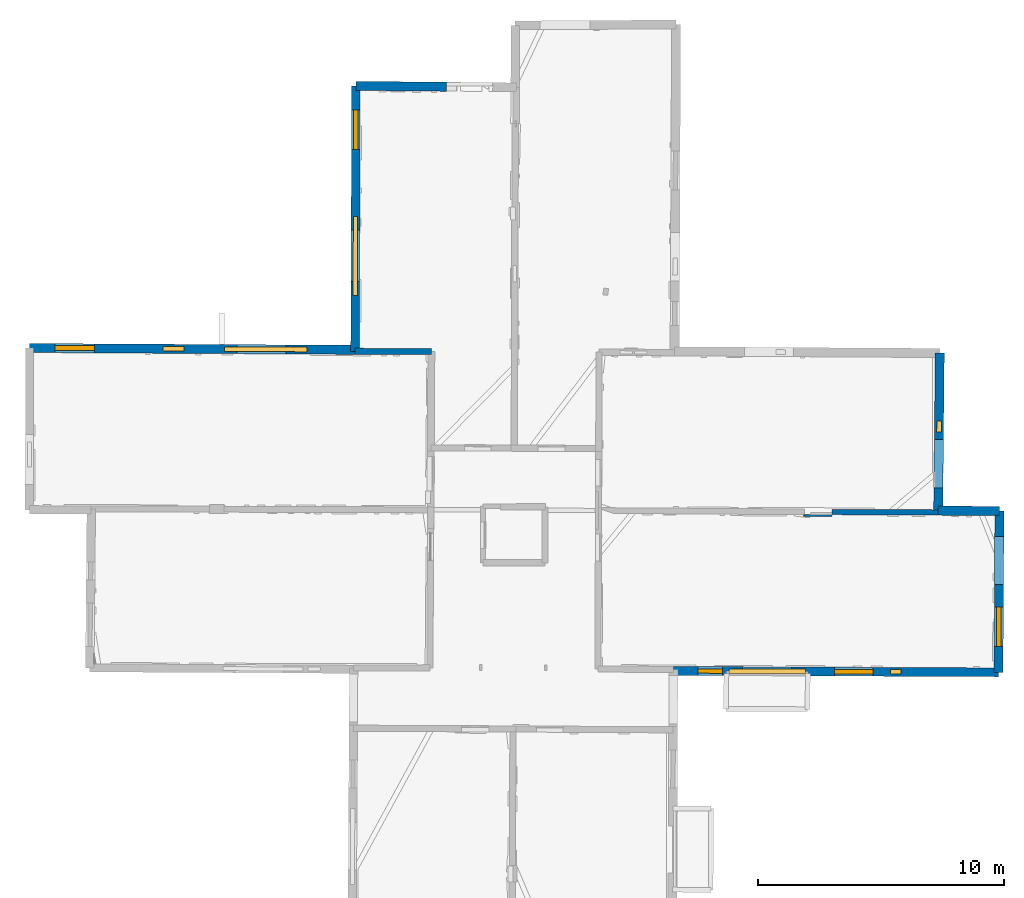
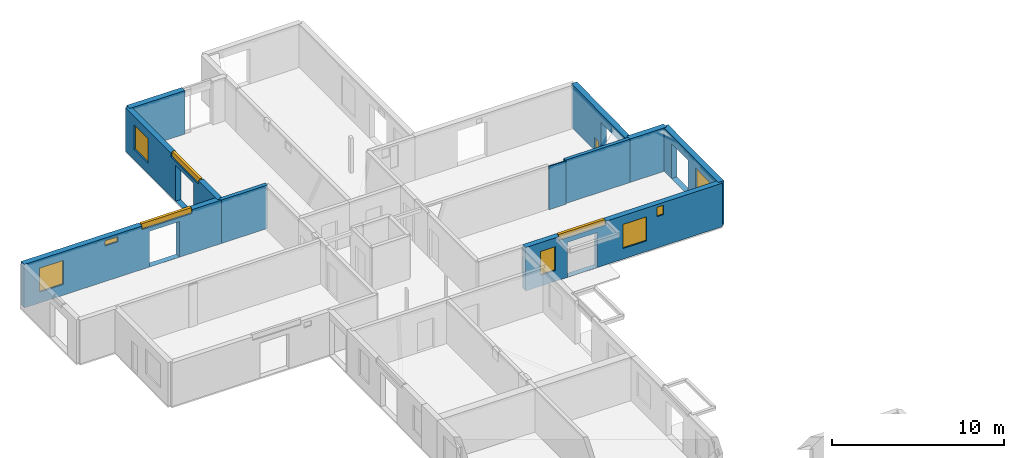
# One storey, part 9 of 15: 11 windows, 10 walls, 16 openings.
"""IFC2X3 building model written with IfcOpenShell, lengths in metres."""

from ifc_helpers import new_model, entity, si_unit, converted_unit, derived_unit, direction, frame, frame_2d, origin, origin_2d_with_axis, place, context, subcontext, project, spatial, polyline, rectangle, outline, extrude, source, transform, mapped, material, layer, layer_set, layer_usage, type_object, type_shapes, element, fill, save


model = new_model("IFC2X3")

# Units and contexts
model_context = context("Model", 3, precision=1e-05, world=origin(), true_north=direction((0.0, 1.0)))
body_context = subcontext(model_context, "Body", "Model", "MODEL_VIEW")
ifc_project = project(units=[si_unit("LENGTHUNIT", "METRE"), si_unit("AREAUNIT", "SQUARE_METRE"), si_unit("VOLUMEUNIT", "CUBIC_METRE"), converted_unit("PLANEANGLEUNIT", "DEGREE", entity("IfcRatioMeasure", 0.0174532925199433), si_unit("PLANEANGLEUNIT", "RADIAN"), dimensions=[0, 0, 0, 0, 0, 0, 0]), si_unit("MASSUNIT", "GRAM", prefix="KILO"), derived_unit("MASSDENSITYUNIT", [(si_unit("MASSUNIT", "GRAM", prefix="KILO"), 1), (si_unit("LENGTHUNIT", "METRE"), -3)]), derived_unit("MOMENTOFINERTIAUNIT", [(si_unit("LENGTHUNIT", "METRE"), 4)]), si_unit("TIMEUNIT", "SECOND"), si_unit("FREQUENCYUNIT", "HERTZ"), si_unit("THERMODYNAMICTEMPERATUREUNIT", "DEGREE_CELSIUS"), derived_unit("THERMALTRANSMITTANCEUNIT", [(si_unit("MASSUNIT", "GRAM", prefix="KILO"), 1), (si_unit("THERMODYNAMICTEMPERATUREUNIT", "KELVIN"), -1), (si_unit("TIMEUNIT", "SECOND"), -3)]), derived_unit("VOLUMETRICFLOWRATEUNIT", [(si_unit("LENGTHUNIT", "METRE"), 3), (si_unit("TIMEUNIT", "SECOND"), -1)]), si_unit("ELECTRICCURRENTUNIT", "AMPERE"), si_unit("ELECTRICVOLTAGEUNIT", "VOLT"), si_unit("POWERUNIT", "WATT"), si_unit("FORCEUNIT", "NEWTON", prefix="KILO"), si_unit("ILLUMINANCEUNIT", "LUX"), si_unit("LUMINOUSFLUXUNIT", "LUMEN"), si_unit("LUMINOUSINTENSITYUNIT", "CANDELA"), derived_unit("USERDEFINED", [(si_unit("MASSUNIT", "GRAM", prefix="KILO"), -1), (si_unit("LENGTHUNIT", "METRE"), -2), (si_unit("TIMEUNIT", "SECOND"), 3), (si_unit("LUMINOUSFLUXUNIT", "LUMEN"), 1)]), derived_unit("LINEARVELOCITYUNIT", [(si_unit("LENGTHUNIT", "METRE"), 1), (si_unit("TIMEUNIT", "SECOND"), -1)]), si_unit("PRESSUREUNIT", "PASCAL"), derived_unit("USERDEFINED", [(si_unit("LENGTHUNIT", "METRE"), -2), (si_unit("MASSUNIT", "GRAM", prefix="KILO"), 1), (si_unit("TIMEUNIT", "SECOND"), -2)]), derived_unit("LINEARFORCEUNIT", [(si_unit("MASSUNIT", "GRAM", prefix="KILO"), 1), (si_unit("LENGTHUNIT", "METRE"), 1), (si_unit("TIMEUNIT", "SECOND"), -2), (si_unit("LENGTHUNIT", "METRE"), -1)]), derived_unit("PLANARFORCEUNIT", [(si_unit("MASSUNIT", "GRAM", prefix="KILO"), 1), (si_unit("LENGTHUNIT", "METRE"), 1), (si_unit("TIMEUNIT", "SECOND"), -2), (si_unit("LENGTHUNIT", "METRE"), -2)])], contexts=[model_context])

# Site, building, storey
placement = place(None, origin())
site = spatial("IfcSite", under=ifc_project, at=placement, CompositionType="ELEMENT")
building = spatial("IfcBuilding", under=site, at=placement, CompositionType="ELEMENT")
storey_placement = place(placement, frame((0.0, 0.0, 2.3807327747345)))
storey = spatial("IfcBuildingStorey", under=building, at=storey_placement, Name="Level 2", CompositionType="ELEMENT", Elevation=2.3807327747345)

# Wall
ifc_material_1 = material(Name="Default wall")
ifc_layer_1 = layer(ifc_material_1, 0.25)
ifc_layer_set_1 = layer_set([ifc_layer_1], Name="wall_thickness_0.2500")
ifc_layer_usage_1 = layer_usage(ifc_layer_set_1, "AXIS2", "POSITIVE", -0.125)
wall_type_1 = type_object("IfcWallType", Name="wall_thickness_0.2500", PredefinedType="STANDARD", material=ifc_layer_set_1)
wall_1_placement = place(storey_placement, frame((-0.0906764365167786, 64.0786910572292, 0.0), z_axis=(0.0, 0.0, 1.0), x_axis=(0.999988151663691, -0.0048679084044511, 0.0)))
element("IfcWallStandardCase", 1, at=wall_1_placement, inside=storey, type_object=wall_type_1, material=ifc_layer_usage_1, Name="Wall:691", ObjectType="Wall", context=body_context, shape_type="SweptSolid", body=[
    extrude(outline(polyline([(3.09695301168057, -0.125), (3.09695301168057, 0.125), (0.0, 0.125), (0.0, -0.125), (3.09695301168057, -0.125)])), origin(), (0.0, 0.0, 1.0), 3.08589615821838),
])

# Wall, openings, windows
ifc_layer_2 = layer(ifc_material_1, 0.349999994039536)
ifc_layer_set_2 = layer_set([ifc_layer_2], Name="wall_thickness_0.3500")
ifc_layer_usage_2 = layer_usage(ifc_layer_set_2, "AXIS2", "POSITIVE", -0.174999997019768)
wall_type_2 = type_object("IfcWallType", Name="wall_thickness_0.3500", PredefinedType="STANDARD", material=ifc_layer_set_2)
wall_2_placement = place(storey_placement, frame((-0.0535053161147532, 74.8457627418778, 0.0), z_axis=(0.0, 0.0, 1.0), x_axis=(-0.00345223117445112, -0.999994041032204, 0.0)))
wall_2 = element("IfcWallStandardCase", 2, at=wall_2_placement, inside=storey, type_object=wall_type_2, material=ifc_layer_usage_2, Name="Wall:695", ObjectType="Wall", context=body_context, shape_type="SweptSolid", body=[
    extrude(outline(polyline([(10.767146375434, -0.174999997019768), (10.767146375434, 0.174999997019768), (0.0, 0.174999997019768), (0.0, -0.174999997019768), (10.767146375434, -0.174999997019768)])), origin(), (0.0, 0.0, 1.0), 3.08589615821838),
])
opening_1_placement = place(wall_2_placement, frame((5.84369326956911, -0.174999997019768, 0.00526785850524902)))
element("IfcOpeningElement", 3, at=opening_1_placement, cuts=wall_2, Name="Opening : 2095 x 2525 : 438", ObjectType="Opening", context=body_context, shape_type="SweptSolid", body=[
    extrude(rectangle(XDim=2.095, YDim=2.525, at=frame_2d((1.2625, 1.0475), x_axis=(0.0, 1.0))), frame((0.0, 0.0, 0.0), z_axis=(0.0, 1.0, 0.0), x_axis=(0.0, 0.0, 1.0)), (0.0, 0.0, 1.0), 0.349999994039536),
])
opening_2_placement = place(wall_2_placement, frame((5.28984933202221, -0.174999997019768, 2.83026766777039)))
opening_2 = element("IfcOpeningElement", 4, at=opening_2_placement, cuts=wall_2, Name="Opening : 3210 x 345 : 439", ObjectType="Opening", context=body_context, shape_type="SweptSolid", body=[
    extrude(rectangle(XDim=3.21, YDim=0.345, at=frame_2d((0.1725, 1.605), x_axis=(0.0, 1.0))), frame((0.0, 0.0, 0.0), z_axis=(0.0, 1.0, 0.0), x_axis=(0.0, 0.0, 1.0)), (0.0, 0.0, 1.0), 0.349999994039536),
])
opening_3_placement = place(wall_2_placement, frame((0.969854412022947, -0.174999997019768, 0.735267639160156)))
opening_3 = element("IfcOpeningElement", 5, at=opening_3_placement, cuts=wall_2, Name="Opening : 1620 x 1745 : 440", ObjectType="Opening", context=body_context, shape_type="SweptSolid", body=[
    extrude(rectangle(XDim=1.62, YDim=1.745, at=frame_2d((0.8725, 0.81), x_axis=(0.0, 1.0))), frame((0.0, 0.0, 0.0), z_axis=(0.0, 1.0, 0.0), x_axis=(0.0, 0.0, 1.0)), (0.0, 0.0, 1.0), 0.349999994039536),
])
ifc_material_2 = material(Name="Window Default")
window_style_1 = type_object("IfcWindowStyle", Name="Window : 3210 x 345mm", ConstructionType="NOTDEFINED", OperationType="NOTDEFINED", ParameterTakesPrecedence=False, Sizeable=False, material=ifc_material_2)
shared_shape_1 = source(origin(), body_context, "Body", "SweptSolid", [
    extrude(rectangle(XDim=0.174999997019768, YDim=3.21, at=origin_2d_with_axis()), frame((1.605, 0.174999997019768, 0.0), z_axis=(0.0, 0.0, 1.0), x_axis=(0.0, 1.0, 0.0)), (0.0, 0.0, 1.0), 0.345),
])
type_shapes(window_style_1, [shared_shape_1])
window_1_placement = place(opening_2_placement, origin())
window_1 = element("IfcWindow", 6, at=window_1_placement, inside=storey, type_object=window_style_1, Name="Window : 3210 x 345mm : 239", ObjectType="Window : 3210 x 345mm", OverallHeight=0.345, OverallWidth=3.21, context=body_context, shape_type="MappedRepresentation", body=[
    mapped(shared_shape_1, transform((0.0, 0.0, 0.0), scale=1.0)),
])
fill(opening_2, window_1)
window_style_2 = type_object("IfcWindowStyle", Name="Window : 1620 x 1745mm", ConstructionType="NOTDEFINED", OperationType="NOTDEFINED", ParameterTakesPrecedence=False, Sizeable=False, material=ifc_material_2)
shared_shape_2 = source(origin(), body_context, "Body", "SweptSolid", [
    extrude(rectangle(XDim=0.174999997019768, YDim=1.62, at=origin_2d_with_axis()), frame((0.81, 0.174999997019768, 0.0), z_axis=(0.0, 0.0, 1.0), x_axis=(0.0, 1.0, 0.0)), (0.0, 0.0, 1.0), 1.745),
])
type_shapes(window_style_2, [shared_shape_2])
window_2_placement = place(opening_3_placement, origin())
window_2 = element("IfcWindow", 7, at=window_2_placement, inside=storey, type_object=window_style_2, Name="Window : 1620 x 1745mm : 240", ObjectType="Window : 1620 x 1745mm", OverallHeight=1.745, OverallWidth=1.62, context=body_context, shape_type="MappedRepresentation", body=[
    mapped(shared_shape_2, transform((0.0, 0.0, 0.0), scale=1.0)),
])
fill(opening_3, window_2)

ifc_layer_3 = layer(ifc_material_1, 0.370000004768372)
ifc_layer_set_3 = layer_set([ifc_layer_3], Name="wall_thickness_0.3700")
ifc_layer_usage_3 = layer_usage(ifc_layer_set_3, "AXIS2", "POSITIVE", -0.185000002384186)
wall_type_3 = type_object("IfcWallType", Name="wall_thickness_0.3700", PredefinedType="STANDARD", material=ifc_layer_set_3)
wall_3_placement = place(storey_placement, frame((-13.2956305764581, 64.2113955876942, 0.0), z_axis=(0.0, 0.0, 1.0), x_axis=(0.999985026061167, -0.00547244492409057, 0.0)))
wall_3 = element("IfcWallStandardCase", 8, at=wall_3_placement, inside=storey, type_object=wall_type_3, material=ifc_layer_usage_3, Name="Wall:727", ObjectType="Wall", context=body_context, shape_type="SweptSolid", body=[
    extrude(outline(polyline([(13.2053635993439, -0.185000002384186), (13.2053635993439, 0.185000002384186), (0.0, 0.185000002384186), (0.0, -0.185000002384186), (13.2053635993439, -0.185000002384186)])), origin(), (0.0, 0.0, 1.0), 3.08589615821838),
])
opening_4_placement = place(wall_3_placement, frame((8.41019351553604, -0.185000002384186, 0.00526785850524902)))
element("IfcOpeningElement", 9, at=opening_4_placement, cuts=wall_3, Name="Opening : 1985 x 2525 : 462", ObjectType="Opening", context=body_context, shape_type="SweptSolid", body=[
    extrude(rectangle(XDim=1.985, YDim=2.525, at=frame_2d((1.2625, 0.9925), x_axis=(0.0, 1.0))), frame((0.0, 0.0, 0.0), z_axis=(0.0, 1.0, 0.0), x_axis=(0.0, 0.0, 1.0)), (0.0, 0.0, 1.0), 0.370000004768372),
])
opening_5_placement = place(wall_3_placement, frame((5.42322892999086, -0.185000002384186, 2.52226710319519)))
opening_5 = element("IfcOpeningElement", 10, at=opening_5_placement, cuts=wall_3, Name="Opening : 850 x 365 : 463", ObjectType="Opening", context=body_context, shape_type="SweptSolid", body=[
    extrude(rectangle(XDim=0.85, YDim=0.365, at=frame_2d((0.1825, 0.425), x_axis=(0.0, 1.0))), frame((0.0, 0.0, 0.0), z_axis=(0.0, 1.0, 0.0), x_axis=(0.0, 0.0, 1.0)), (0.0, 0.0, 1.0), 0.370000004768372),
])
opening_6_placement = place(wall_3_placement, frame((1.04019153019943, -0.185000002384186, 0.765267610549927)))
opening_6 = element("IfcOpeningElement", 11, at=opening_6_placement, cuts=wall_3, Name="Opening : 1590 x 1705 : 464", ObjectType="Opening", context=body_context, shape_type="SweptSolid", body=[
    extrude(rectangle(XDim=1.59, YDim=1.705, at=frame_2d((0.8525, 0.795), x_axis=(0.0, 1.0))), frame((0.0, 0.0, 0.0), z_axis=(0.0, 1.0, 0.0), x_axis=(0.0, 0.0, 1.0)), (0.0, 0.0, 1.0), 0.370000004768372),
])
opening_7_placement = place(wall_3_placement, frame((7.9017835414809, -0.185000002384186, 2.82026743888855)))
opening_7 = element("IfcOpeningElement", 12, at=opening_7_placement, cuts=wall_3, Name="Opening : 3350 x 355 : 465", ObjectType="Opening", context=body_context, shape_type="SweptSolid", body=[
    extrude(rectangle(XDim=3.35, YDim=0.355, at=frame_2d((0.1775, 1.675), x_axis=(0.0, 1.0))), frame((0.0, 0.0, 0.0), z_axis=(0.0, 1.0, 0.0), x_axis=(0.0, 0.0, 1.0)), (0.0, 0.0, 1.0), 0.370000004768372),
])
window_style_3 = type_object("IfcWindowStyle", Name="Window : 1590 x 1705mm", ConstructionType="NOTDEFINED", OperationType="NOTDEFINED", ParameterTakesPrecedence=False, Sizeable=False, material=ifc_material_2)
shared_shape_3 = source(origin(), body_context, "Body", "SweptSolid", [
    extrude(rectangle(XDim=0.194999992847443, YDim=1.59, at=origin_2d_with_axis()), frame((0.795, 0.194999992847443, 0.0), z_axis=(0.0, 0.0, 1.0), x_axis=(0.0, 1.0, 0.0)), (0.0, 0.0, 1.0), 1.705),
])
type_shapes(window_style_3, [shared_shape_3])
window_3_placement = place(opening_6_placement, origin())
window_3 = element("IfcWindow", 13, at=window_3_placement, inside=storey, type_object=window_style_3, Name="Window : 1590 x 1705mm : 252", ObjectType="Window : 1590 x 1705mm", OverallHeight=1.705, OverallWidth=1.59, context=body_context, shape_type="MappedRepresentation", body=[
    mapped(shared_shape_3, transform((0.0, 0.0, 0.0), scale=1.0)),
])
fill(opening_6, window_3)
window_style_4 = type_object("IfcWindowStyle", Name="Window : 850 x 365mm", ConstructionType="NOTDEFINED", OperationType="NOTDEFINED", ParameterTakesPrecedence=False, Sizeable=False, material=ifc_material_2)
shared_shape_4 = source(origin(), body_context, "Body", "SweptSolid", [
    extrude(rectangle(XDim=0.185000002384186, YDim=0.85, at=origin_2d_with_axis()), frame((0.425, 0.185000002384186, 0.0), z_axis=(0.0, 0.0, 1.0), x_axis=(0.0, 1.0, 0.0)), (0.0, 0.0, 1.0), 0.365),
])
type_shapes(window_style_4, [shared_shape_4])
window_4_placement = place(opening_5_placement, origin())
window_4 = element("IfcWindow", 14, at=window_4_placement, inside=storey, type_object=window_style_4, Name="Window : 850 x 365mm : 251", ObjectType="Window : 850 x 365mm", OverallHeight=0.365, OverallWidth=0.85, context=body_context, shape_type="MappedRepresentation", body=[
    mapped(shared_shape_4, transform((0.0, 0.0, 0.0), scale=1.0)),
])
fill(opening_5, window_4)
window_style_5 = type_object("IfcWindowStyle", Name="Window : 3350 x 355mm", ConstructionType="NOTDEFINED", OperationType="NOTDEFINED", ParameterTakesPrecedence=False, Sizeable=False, material=ifc_material_2)
shared_shape_5 = source(origin(), body_context, "Body", "SweptSolid", [
    extrude(rectangle(XDim=0.185000002384186, YDim=3.35, at=origin_2d_with_axis()), frame((1.675, 0.185000002384186, 0.0), z_axis=(0.0, 0.0, 1.0), x_axis=(0.0, 1.0, 0.0)), (0.0, 0.0, 1.0), 0.355),
])
type_shapes(window_style_5, [shared_shape_5])
window_5_placement = place(opening_7_placement, origin())
window_5 = element("IfcWindow", 15, at=window_5_placement, inside=storey, type_object=window_style_5, Name="Window : 3350 x 355mm : 253", ObjectType="Window : 3350 x 355mm", OverallHeight=0.355, OverallWidth=3.35, context=body_context, shape_type="MappedRepresentation", body=[
    mapped(shared_shape_5, transform((0.0, 0.0, 0.0), scale=1.0)),
])
fill(opening_7, window_5)

# Wall, openings, window
wall_4_placement = place(storey_placement, frame((23.6338339024717, 64.0098037092952, 0.0), z_axis=(0.0, 0.0, 1.0), x_axis=(-0.00993887533484654, -0.999950608158762, 0.0)))
wall_4 = element("IfcWallStandardCase", 16, at=wall_4_placement, inside=storey, type_object=wall_type_3, material=ifc_layer_usage_3, Name="Wall:732", ObjectType="Wall", context=body_context, shape_type="SweptSolid", body=[
    extrude(outline(polyline([(6.39801727328113, -0.185000002384186), (6.39801727328113, 0.185000002384186), (0.0, 0.185000002384186), (0.0, -0.185000002384186), (6.39801727328113, -0.185000002384186)])), origin(), (0.0, 0.0, 1.0), 3.08589615821838),
])
opening_8_placement = place(wall_4_placement, frame((3.50378744257806, -0.185000002384186, 0.00526785850524902)))
element("IfcOpeningElement", 17, at=opening_8_placement, cuts=wall_4, Name="Opening : 1970 x 2450 : 471", ObjectType="Opening", context=body_context, shape_type="SweptSolid", body=[
    extrude(rectangle(XDim=1.97, YDim=2.45, at=frame_2d((1.225, 0.985), x_axis=(0.0, 1.0))), frame((0.0, 0.0, 0.0), z_axis=(0.0, 1.0, 0.0), x_axis=(0.0, 0.0, 1.0)), (0.0, 0.0, 1.0), 0.370000004768372),
])
opening_9_placement = place(wall_4_placement, frame((2.75626248104997, -0.185000002384186, 0.0972676277160645)))
opening_9 = element("IfcOpeningElement", 18, at=opening_9_placement, cuts=wall_4, Name="Opening : 445 x 825 : 472", ObjectType="Opening", context=body_context, shape_type="SweptSolid", body=[
    extrude(rectangle(XDim=0.445, YDim=0.825, at=frame_2d((0.4125, 0.2225), x_axis=(0.0, 1.0))), frame((0.0, 0.0, 0.0), z_axis=(0.0, 1.0, 0.0), x_axis=(0.0, 0.0, 1.0)), (0.0, 0.0, 1.0), 0.370000004768372),
])
window_style_6 = type_object("IfcWindowStyle", Name="Window : 445 x 825mm", ConstructionType="NOTDEFINED", OperationType="NOTDEFINED", ParameterTakesPrecedence=False, Sizeable=False, material=ifc_material_2)
shared_shape_6 = source(origin(), body_context, "Body", "SweptSolid", [
    extrude(rectangle(XDim=0.185000002384186, YDim=0.445, at=origin_2d_with_axis()), frame((0.2225, 0.185000002384186, 0.0), z_axis=(0.0, 0.0, 1.0), x_axis=(0.0, 1.0, 0.0)), (0.0, 0.0, 1.0), 0.825),
])
type_shapes(window_style_6, [shared_shape_6])
window_6_placement = place(opening_9_placement, origin())
window_6 = element("IfcWindow", 19, at=window_6_placement, inside=storey, type_object=window_style_6, Name="Window : 445 x 825mm : 258", ObjectType="Window : 445 x 825mm", OverallHeight=0.825, OverallWidth=0.445, context=body_context, shape_type="MappedRepresentation", body=[
    mapped(shared_shape_6, transform((0.0, 0.0, 0.0), scale=1.0)),
])
fill(opening_9, window_6)

wall_5_placement = place(storey_placement, frame((26.0540302055587, 57.6021826031562, 0.0), z_axis=(0.0, 0.0, 1.0), x_axis=(-0.0058675588837642, -0.999982785728207, 0.0)))
wall_5 = element("IfcWallStandardCase", 20, at=wall_5_placement, inside=storey, type_object=wall_type_3, material=ifc_layer_usage_3, Name="Wall:770", ObjectType="Wall", context=body_context, shape_type="SweptSolid", body=[
    extrude(outline(polyline([(6.54879589925643, -0.185000002384186), (6.54879589925643, 0.185000002384186), (0.0, 0.185000002384186), (0.0, -0.185000002384186), (6.54879589925643, -0.185000002384186)])), origin(), (0.0, 0.0, 1.0), 3.08589615821838),
])
opening_10_placement = place(wall_5_placement, frame((1.03357187199044, -0.185000002384186, 0.00526785850524902)))
element("IfcOpeningElement", 21, at=opening_10_placement, cuts=wall_5, Name="Opening : 1945 x 2475 : 487", ObjectType="Opening", context=body_context, shape_type="SweptSolid", body=[
    extrude(rectangle(XDim=1.945, YDim=2.475, at=frame_2d((1.2375, 0.9725), x_axis=(0.0, 1.0))), frame((0.0, 0.0, 0.0), z_axis=(0.0, 1.0, 0.0), x_axis=(0.0, 0.0, 1.0)), (0.0, 0.0, 1.0), 0.370000004768372),
])
opening_11_placement = place(wall_5_placement, frame((3.89857327184577, -0.185000002384186, 0.750267744064331)))
opening_11 = element("IfcOpeningElement", 22, at=opening_11_placement, cuts=wall_5, Name="Opening : 1610 x 1735 : 488", ObjectType="Opening", context=body_context, shape_type="SweptSolid", body=[
    extrude(rectangle(XDim=1.61, YDim=1.735, at=frame_2d((0.8675, 0.805), x_axis=(0.0, 1.0))), frame((0.0, 0.0, 0.0), z_axis=(0.0, 1.0, 0.0), x_axis=(0.0, 0.0, 1.0)), (0.0, 0.0, 1.0), 0.370000004768372),
])
window_style_7 = type_object("IfcWindowStyle", Name="Window : 1610 x 1735mm", ConstructionType="NOTDEFINED", OperationType="NOTDEFINED", ParameterTakesPrecedence=False, Sizeable=False, material=ifc_material_2)
shared_shape_7 = source(origin(), body_context, "Body", "SweptSolid", [
    extrude(rectangle(XDim=0.185000002384186, YDim=1.61, at=origin_2d_with_axis()), frame((0.805, 0.185000002384186, 0.0), z_axis=(0.0, 0.0, 1.0), x_axis=(0.0, 1.0, 0.0)), (0.0, 0.0, 1.0), 1.735),
])
type_shapes(window_style_7, [shared_shape_7])
window_7_placement = place(opening_11_placement, origin())
window_7 = element("IfcWindow", 23, at=window_7_placement, inside=storey, type_object=window_style_7, Name="Window : 1610 x 1735mm : 262", ObjectType="Window : 1610 x 1735mm", OverallHeight=1.735, OverallWidth=1.61, context=body_context, shape_type="MappedRepresentation", body=[
    mapped(shared_shape_7, transform((0.0, 0.0, 0.0), scale=1.0)),
])
fill(opening_11, window_7)

# Walls
wall_6_placement = place(storey_placement, frame((-0.0535056053142751, 74.8457545391569, 0.0), z_axis=(0.0, 0.0, 1.0), x_axis=(0.999956328217215, -0.00934567591699247, 0.0)))
element("IfcWallStandardCase", 24, at=wall_6_placement, inside=storey, type_object=wall_type_3, material=ifc_layer_usage_3, Name="Wall:776", ObjectType="Wall", context=body_context, shape_type="SweptSolid", body=[
    extrude(outline(polyline([(3.67686545884509, -0.185000002384186), (3.67686545884509, 0.185000002384186), (0.0, 0.185000002384186), (0.0, -0.185000002384186), (3.67686545884509, -0.185000002384186)])), origin(), (0.0, 0.0, 1.0), 3.08589615821838),
])
wall_7_placement = place(storey_placement, frame((23.5702423383053, 57.6121091727195, 0.0), z_axis=(0.0, 0.0, 1.0), x_axis=(0.999992002823346, -0.00399928610536758, 0.0)))
element("IfcWallStandardCase", 25, at=wall_7_placement, inside=storey, type_object=wall_type_3, material=ifc_layer_usage_3, Name="Wall:793", ObjectType="Wall", context=body_context, shape_type="SweptSolid", body=[
    extrude(outline(polyline([(2.48381121479542, -0.185000002384186), (2.48381121479542, 0.185000002384186), (0.0, 0.185000002384186), (0.0, -0.185000002384186), (2.48381121479542, -0.185000002384186)])), origin(), (0.0, 0.0, 1.0), 3.08589615821838),
])

# Wall, openings, windows
ifc_layer_4 = layer(ifc_material_1, 0.360000014305115)
ifc_layer_set_4 = layer_set([ifc_layer_4], Name="wall_thickness_0.3600")
ifc_layer_usage_4 = layer_usage(ifc_layer_set_4, "AXIS2", "POSITIVE", -0.180000007152557)
wall_type_4 = type_object("IfcWallType", Name="wall_thickness_0.3600", PredefinedType="STANDARD", material=ifc_layer_set_4)
wall_8_placement = place(storey_placement, frame((12.8278243343549, 51.1126649744231, 0.0), z_axis=(0.0, 0.0, 1.0), x_axis=(0.999989936164332, -0.00448637604913739, 0.0)))
wall_8 = element("IfcWallStandardCase", 26, at=wall_8_placement, inside=storey, type_object=wall_type_4, material=ifc_layer_usage_4, Name="Wall:711", ObjectType="Wall", context=body_context, shape_type="SweptSolid", body=[
    extrude(outline(polyline([(13.1879169159749, -0.180000007152557), (13.1879169159749, 0.180000007152557), (0.0, 0.180000007152557), (0.0, -0.180000007152557), (13.1879169159749, -0.180000007152557)])), origin(), (0.0, 0.0, 1.0), 3.08589615821838),
])
opening_12_placement = place(wall_8_placement, frame((2.7985416494574, -0.180000007152557, 0.00526785850524902)))
element("IfcOpeningElement", 27, at=opening_12_placement, cuts=wall_8, Name="Opening : 2000 x 2480 : 449", ObjectType="Opening", context=body_context, shape_type="SweptSolid", body=[
    extrude(rectangle(XDim=2.0, YDim=2.48, at=frame_2d((1.24, 1.0), x_axis=(0.0, 1.0))), frame((0.0, 0.0, 0.0), z_axis=(0.0, 1.0, 0.0), x_axis=(0.0, 0.0, 1.0)), (0.0, 0.0, 1.0), 0.360000014305115),
])
opening_13_placement = place(wall_8_placement, frame((2.24581317396792, -0.180000007152557, 2.82026743888855)))
opening_13 = element("IfcOpeningElement", 28, at=opening_13_placement, cuts=wall_8, Name="Opening : 3105 x 355 : 450", ObjectType="Opening", context=body_context, shape_type="SweptSolid", body=[
    extrude(rectangle(XDim=3.105, YDim=0.355, at=frame_2d((0.1775, 1.5525), x_axis=(0.0, 1.0))), frame((0.0, 0.0, 0.0), z_axis=(0.0, 1.0, 0.0), x_axis=(0.0, 0.0, 1.0)), (0.0, 0.0, 1.0), 0.360000014305115),
])
opening_14_placement = place(wall_8_placement, frame((8.79695596446889, -0.180000007152557, 2.2272675037384)))
opening_14 = element("IfcOpeningElement", 29, at=opening_14_placement, cuts=wall_8, Name="Opening : 435 x 655 : 451", ObjectType="Opening", context=body_context, shape_type="SweptSolid", body=[
    extrude(rectangle(XDim=0.435, YDim=0.655, at=frame_2d((0.3275, 0.2175), x_axis=(0.0, 1.0))), frame((0.0, 0.0, 0.0), z_axis=(0.0, 1.0, 0.0), x_axis=(0.0, 0.0, 1.0)), (0.0, 0.0, 1.0), 0.360000014305115),
])
opening_15_placement = place(wall_8_placement, frame((0.998539538124343, -0.180000007152557, 0.775267839431763)))
opening_15 = element("IfcOpeningElement", 30, at=opening_15_placement, cuts=wall_8, Name="Opening : 990 x 1690 : 452", ObjectType="Opening", context=body_context, shape_type="SweptSolid", body=[
    extrude(rectangle(XDim=0.99, YDim=1.69, at=frame_2d((0.845, 0.495), x_axis=(0.0, 1.0))), frame((0.0, 0.0, 0.0), z_axis=(0.0, 1.0, 0.0), x_axis=(0.0, 0.0, 1.0)), (0.0, 0.0, 1.0), 0.360000014305115),
])
opening_16_placement = place(wall_8_placement, frame((6.52854056973658, -0.180000007152557, 0.750267744064331)))
opening_16 = element("IfcOpeningElement", 31, at=opening_16_placement, cuts=wall_8, Name="Opening : 1565 x 1715 : 453", ObjectType="Opening", context=body_context, shape_type="SweptSolid", body=[
    extrude(rectangle(XDim=1.565, YDim=1.715, at=frame_2d((0.8575, 0.7825), x_axis=(0.0, 1.0))), frame((0.0, 0.0, 0.0), z_axis=(0.0, 1.0, 0.0), x_axis=(0.0, 0.0, 1.0)), (0.0, 0.0, 1.0), 0.360000014305115),
])
window_style_8 = type_object("IfcWindowStyle", Name="Window : 3105 x 355mm", ConstructionType="NOTDEFINED", OperationType="NOTDEFINED", ParameterTakesPrecedence=False, Sizeable=False, material=ifc_material_2)
shared_shape_8 = source(origin(), body_context, "Body", "SweptSolid", [
    extrude(rectangle(XDim=0.180000007152557, YDim=3.105, at=origin_2d_with_axis()), frame((1.5525, 0.180000007152557, 0.0), z_axis=(0.0, 0.0, 1.0), x_axis=(0.0, 1.0, 0.0)), (0.0, 0.0, 1.0), 0.355),
])
type_shapes(window_style_8, [shared_shape_8])
window_8_placement = place(opening_13_placement, origin())
window_8 = element("IfcWindow", 32, at=window_8_placement, inside=storey, type_object=window_style_8, Name="Window : 3105 x 355mm : 243", ObjectType="Window : 3105 x 355mm", OverallHeight=0.355, OverallWidth=3.105, context=body_context, shape_type="MappedRepresentation", body=[
    mapped(shared_shape_8, transform((0.0, 0.0, 0.0), scale=1.0)),
])
fill(opening_13, window_8)
window_style_9 = type_object("IfcWindowStyle", Name="Window : 435 x 655mm", ConstructionType="NOTDEFINED", OperationType="NOTDEFINED", ParameterTakesPrecedence=False, Sizeable=False, material=ifc_material_2)
shared_shape_9 = source(origin(), body_context, "Body", "SweptSolid", [
    extrude(rectangle(XDim=0.180000007152557, YDim=0.435, at=origin_2d_with_axis()), frame((0.2175, 0.180000007152557, 0.0), z_axis=(0.0, 0.0, 1.0), x_axis=(0.0, 1.0, 0.0)), (0.0, 0.0, 1.0), 0.655),
])
type_shapes(window_style_9, [shared_shape_9])
window_9_placement = place(opening_14_placement, origin())
window_9 = element("IfcWindow", 33, at=window_9_placement, inside=storey, type_object=window_style_9, Name="Window : 435 x 655mm : 244", ObjectType="Window : 435 x 655mm", OverallHeight=0.655, OverallWidth=0.435, context=body_context, shape_type="MappedRepresentation", body=[
    mapped(shared_shape_9, transform((0.0, 0.0, 0.0), scale=1.0)),
])
fill(opening_14, window_9)
window_style_10 = type_object("IfcWindowStyle", Name="Window : 990 x 1690mm", ConstructionType="NOTDEFINED", OperationType="NOTDEFINED", ParameterTakesPrecedence=False, Sizeable=False, material=ifc_material_2)
shared_shape_10 = source(origin(), body_context, "Body", "SweptSolid", [
    extrude(rectangle(XDim=0.180000007152557, YDim=0.99, at=origin_2d_with_axis()), frame((0.495, 0.180000007152557, 0.0), z_axis=(0.0, 0.0, 1.0), x_axis=(0.0, 1.0, 0.0)), (0.0, 0.0, 1.0), 1.69),
])
type_shapes(window_style_10, [shared_shape_10])
window_10_placement = place(opening_15_placement, origin())
window_10 = element("IfcWindow", 34, at=window_10_placement, inside=storey, type_object=window_style_10, Name="Window : 990 x 1690mm : 245", ObjectType="Window : 990 x 1690mm", OverallHeight=1.69, OverallWidth=0.99, context=body_context, shape_type="MappedRepresentation", body=[
    mapped(shared_shape_10, transform((0.0, 0.0, 0.0), scale=1.0)),
])
fill(opening_15, window_10)
window_style_11 = type_object("IfcWindowStyle", Name="Window : 1565 x 1715mm", ConstructionType="NOTDEFINED", OperationType="NOTDEFINED", ParameterTakesPrecedence=False, Sizeable=False, material=ifc_material_2)
shared_shape_11 = source(origin(), body_context, "Body", "SweptSolid", [
    extrude(rectangle(XDim=0.180000007152557, YDim=1.565, at=origin_2d_with_axis()), frame((0.7825, 0.180000007152557, 0.0), z_axis=(0.0, 0.0, 1.0), x_axis=(0.0, 1.0, 0.0)), (0.0, 0.0, 1.0), 1.715),
])
type_shapes(window_style_11, [shared_shape_11])
window_11_placement = place(opening_16_placement, origin())
window_11 = element("IfcWindow", 35, at=window_11_placement, inside=storey, type_object=window_style_11, Name="Window : 1565 x 1715mm : 246", ObjectType="Window : 1565 x 1715mm", OverallHeight=1.715, OverallWidth=1.565, context=body_context, shape_type="MappedRepresentation", body=[
    mapped(shared_shape_11, transform((0.0, 0.0, 0.0), scale=1.0)),
])
fill(opening_16, window_11)

# Walls
ifc_layer_5 = layer(ifc_material_1, 0.0700000002980232)
ifc_layer_set_5 = layer_set([ifc_layer_5], Name="wall_thickness_0.0700")
ifc_layer_usage_5 = layer_usage(ifc_layer_set_5, "AXIS2", "POSITIVE", -0.0350000001490116)
wall_type_5 = type_object("IfcWallType", Name="wall_thickness_0.0700", PredefinedType="STANDARD", material=ifc_layer_set_5)
wall_9_placement = place(storey_placement, frame((18.1204294227528, 57.4190752465264, 0.0), z_axis=(0.0, 0.0, 1.0), x_axis=(0.999988932705818, -0.00470472803458257, 0.0)))
element("IfcWallStandardCase", 36, at=wall_9_placement, inside=storey, type_object=wall_type_5, material=ifc_layer_usage_5, Name="Wall:813", ObjectType="Wall", context=body_context, shape_type="SweptSolid", body=[
    extrude(outline(polyline([(1.13190759246193, -0.0350000001490116), (1.13190759246193, 0.0350000001490116), (0.0, 0.0350000001490116), (0.0, -0.0350000001490116), (1.13190759246193, -0.0350000001490116)])), origin(), (0.0, 0.0, 1.0), 3.08589615821838),
])
ifc_layer_6 = layer(ifc_material_1, 0.219999998807907)
ifc_layer_set_6 = layer_set([ifc_layer_6], Name="wall_thickness_0.2200")
ifc_layer_usage_6 = layer_usage(ifc_layer_set_6, "AXIS2", "POSITIVE", -0.109999999403954)
wall_type_6 = type_object("IfcWallType", Name="wall_thickness_0.2200", PredefinedType="STANDARD", material=ifc_layer_set_6)
wall_10_placement = place(storey_placement, frame((19.2530061844192, 57.5587521409369, 0.0), z_axis=(0.0, 0.0, 1.0), x_axis=(0.999988956298371, -0.00469971076716223, 0.0)))
element("IfcWallStandardCase", 37, at=wall_10_placement, inside=storey, type_object=wall_type_6, material=ifc_layer_usage_6, Name="Wall:814", ObjectType="Wall", context=body_context, shape_type="SweptSolid", body=[
    extrude(outline(polyline([(4.31655501022314, -0.109999999403954), (4.31655501022314, 0.109999999403954), (0.0, 0.109999999403954), (0.0, -0.109999999403954), (4.31655501022314, -0.109999999403954)])), origin(), (0.0, 0.0, 1.0), 3.08589615821838),
])

save(model, "model.ifc")
